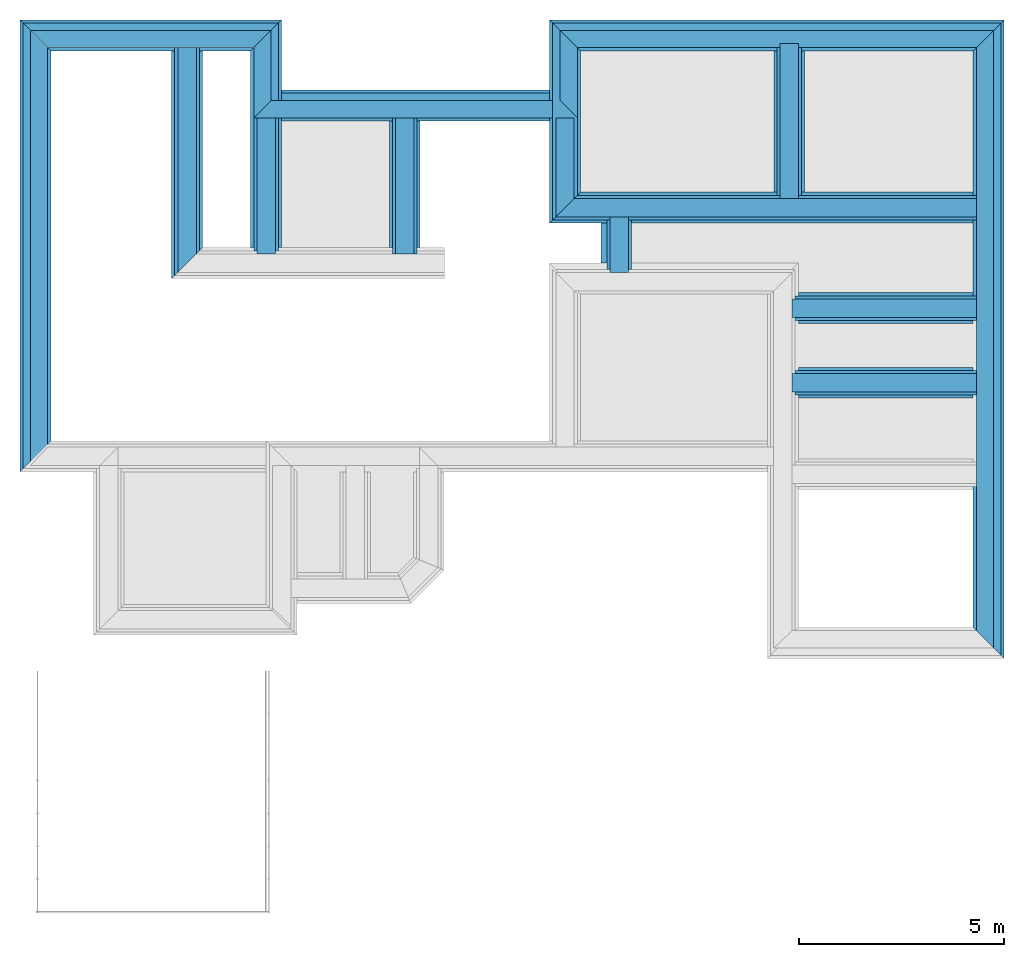
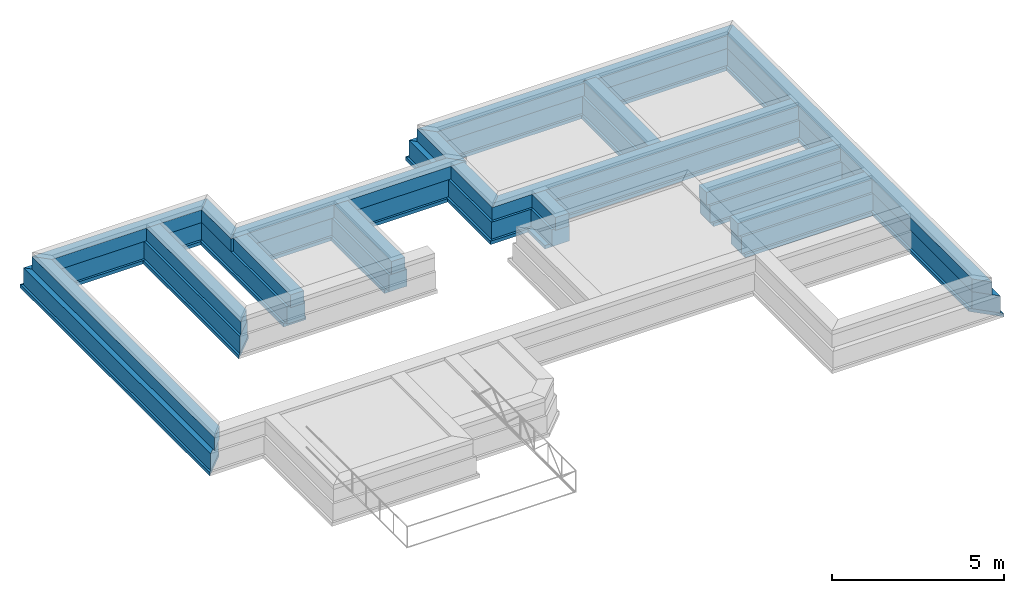
# One storey, part 6 of 7: 44 walls.
"""IFC4X3_ADD2 building model written with IfcOpenShell, lengths in metres."""

from ifc_helpers import new_model, entity, si_unit, converted_unit, frame, origin_with_axes, origin_2d_with_axis, place, context, subcontext, project, spatial, line, indexed_curve, outline, extrude, material, layer, layer_set, layer_usage, type_object, element, save


model = new_model("IFC4X3_ADD2")

# Units and contexts
model_context = context("Model", 3, precision=1e-05, world=origin_with_axes())
plan_context = context("Plan", 2, precision=1e-05, world=origin_2d_with_axis())
body_context = subcontext(model_context, "Body", "Model", "MODEL_VIEW")
ifc_project = project(units=[si_unit("VOLUMEUNIT", "CUBIC_METRE"), si_unit("LENGTHUNIT", "METRE"), converted_unit("PLANEANGLEUNIT", "degree", entity("IfcReal", 0.0174532925199433), si_unit("PLANEANGLEUNIT", "RADIAN"), dimensions=[0, 0, 0, 0, 0, 0, 0]), si_unit("AREAUNIT", "SQUARE_METRE")], contexts=[model_context, plan_context])

# Site, building, storey
site_placement = place(None, origin_with_axes())
site = spatial("IfcSite", under=ifc_project, at=site_placement)
building_placement = place(site_placement, origin_with_axes())
building = spatial("IfcBuilding", under=site, at=building_placement, Name="Building")
storey_placement = place(building_placement, frame((0.0, 0.0, -0.870000004768372), z_axis=(0.0, 0.0, 1.0), x_axis=(1.0, 0.0, 0.0)))
storey = spatial("IfcBuildingStorey", under=building, at=storey_placement, Name="Footing")

# Walls
ifc_material_1 = material(Name="Stone", Category="Structure")
ifc_layer_1 = layer(ifc_material_1, 0.449999988079071)
ifc_layer_set_1 = layer_set([ifc_layer_1])
ifc_layer_usage_1 = layer_usage(ifc_layer_set_1, "AXIS2", "POSITIVE", 0.0)
wall_type_1 = type_object("IfcWallType", Name="RRB_0.45W", PredefinedType="SHEAR", material=ifc_layer_set_1)
wall_1_placement = place(storey_placement, frame((23.9316806793215, 21.8778921531674, 0.719999998807908), z_axis=(0.0, 0.0, 1.0), x_axis=(3.13916473260163e-07, 0.999999999999951, 0.0)))
element("IfcWall", 1, at=wall_1_placement, inside=storey, type_object=wall_type_1, material=ifc_layer_usage_1, Name="Wall", context=body_context, shape_type="SweptSolid", body=[
    extrude(outline(indexed_curve([(0.44999998807909, 0.0), (0.450000117880316, 0.449999988079071), (4.22000942370352, 0.449999988079071), (4.22000939257221, 0.0)], segments=[line(1, 2, 3, 4, 1)])), origin_with_axes(), (0.0, 0.0, 1.0), 0.449999988079071),
])
ifc_layer_usage_2 = layer_usage(ifc_layer_set_1, "AXIS2", "POSITIVE", 0.0)
wall_2_placement = place(storey_placement, frame((18.4541816711426, 21.8778954520824, 0.719999998807908), z_axis=(0.0, 0.0, 1.0), x_axis=(0.999999999999822, -5.960464477538e-07, 0.0)))
element("IfcWall", 2, at=wall_2_placement, inside=storey, type_object=wall_type_1, material=ifc_layer_usage_2, Name="Wall", context=body_context, shape_type="SweptSolid", body=[
    extrude(outline(indexed_curve([(-0.449999988079037, 0.0), (5.60801341516185e-08, 0.449999988079071), (9.80748997480777, 0.449999988079071), (9.80749009981741, 0.0)], segments=[line(1, 2, 3, 4, 1)])), origin_with_axes(), (0.0, 0.0, 1.0), 0.449999988079071),
])
ifc_layer_usage_3 = layer_usage(ifc_layer_set_1, "AXIS2", "POSITIVE", 0.0)
wall_3_placement = place(storey_placement, frame((11.1843014234303, 20.5243861418143, 0.719999998807908), z_axis=(0.0, 0.0, 1.0), x_axis=(3.13916473260163e-07, 0.999999999999951, 0.0)))
element("IfcWall", 3, at=wall_3_placement, inside=storey, type_object=wall_type_1, material=ifc_layer_usage_3, Name="Wall", context=body_context, shape_type="SweptSolid", body=[
    extrude(outline(indexed_curve([(0.449999988079093, 0.0), (0.450000131326058, 0.449999988079071), (3.76552144418195, 0.449999988079071), (3.76552141414186, 0.0)], segments=[line(1, 2, 3, 4, 1)])), origin_with_axes(), (0.0, 0.0, 1.0), 0.449999988079071),
])
ifc_layer_usage_4 = layer_usage(ifc_layer_set_1, "AXIS2", "POSITIVE", 0.0)
wall_4_placement = place(storey_placement, frame((14.5602179044483, 20.5243840074145, 0.719999998807908), z_axis=(0.0, 0.0, 1.0), x_axis=(3.13916473260163e-07, 0.999999999999951, 0.0)))
element("IfcWall", 4, at=wall_4_placement, inside=storey, type_object=wall_type_1, material=ifc_layer_usage_4, Name="Wall", context=body_context, shape_type="SweptSolid", body=[
    extrude(outline(indexed_curve([(0.449999988079094, 0.0), (0.450000131326058, 0.449999988079071), (3.76552229320457, 0.449999988079071), (3.76552226325902, 0.0)], segments=[line(1, 2, 3, 4, 1)])), origin_with_axes(), (0.0, 0.0, 1.0), 0.449999988079071),
])
ifc_layer_usage_5 = layer_usage(ifc_layer_set_1, "AXIS2", "POSITIVE", 0.0)
wall_5_placement = place(storey_placement, frame((9.25813584268061, 20.5243873596191, 0.719999998807908), z_axis=(0.0, 0.0, 1.0), x_axis=(3.13916473260163e-07, 0.999999999999951, 0.0)))
element("IfcWall", 5, at=wall_5_placement, inside=storey, type_object=wall_type_1, material=ifc_layer_usage_5, Name="Wall", context=body_context, shape_type="SweptSolid", body=[
    extrude(outline(indexed_curve([(0.449999988079093, 0.0), (1.43246964352757e-07, 0.449999988079071), (5.57351498957041, 0.449999988079071), (5.57351496081623, 0.0)], segments=[line(1, 2, 3, 4, 1)])), origin_with_axes(), (0.0, 0.0, 1.0), 0.449999988079071),
])
ifc_layer_usage_6 = layer_usage(ifc_layer_set_1, "AXIS2", "POSITIVE", 0.0)
wall_6_placement = place(storey_placement, frame((23.7750180072631, 19.429594129323, 0.719999998807908), z_axis=(0.0, 0.0, 1.0), x_axis=(0.999999999999822, -5.960464477538e-07, 0.0)))
element("IfcWall", 6, at=wall_6_placement, inside=storey, type_object=wall_type_1, material=ifc_layer_usage_6, Name="Wall", context=body_context, shape_type="SweptSolid", body=[
    extrude(outline(indexed_curve([(0.0, 0.0), (-9.81330211661046e-08, 0.449999988079071), (4.48665286418751, 0.449999988079071), (4.48665298921001, 0.0)], segments=[line(1, 2, 3, 4, 1)])), origin_with_axes(), (0.0, 0.0, 1.0), 0.449999988079071),
])
ifc_layer_usage_7 = layer_usage(ifc_layer_set_1, "AXIS2", "POSITIVE", 0.0)
wall_7_placement = place(storey_placement, frame((19.7916831970215, 20.0728931427002, 0.719999998807908), z_axis=(0.0, 0.0, 1.0), x_axis=(3.13916473260163e-07, 0.999999999999951, 0.0)))
element("IfcWall", 7, at=wall_7_placement, inside=storey, type_object=wall_type_1, material=ifc_layer_usage_7, Name="Wall", context=body_context, shape_type="SweptSolid", body=[
    extrude(outline(indexed_curve([(0.449999988079079, 0.0), (0.450000081867921, 0.449999988079071), (1.80500099995072, 0.449999988079071), (1.80500087014949, 0.0)], segments=[line(1, 2, 3, 4, 1)])), origin_with_axes(), (0.0, 0.0, 1.0), 0.449999988079071),
])
ifc_layer_usage_8 = layer_usage(ifc_layer_set_1, "AXIS2", "POSITIVE", 0.0)
wall_8_placement = place(storey_placement, frame((18.466682434082, 21.8778953552246, 0.719999998807908), z_axis=(0.0, 0.0, 1.0), x_axis=(3.13916473260163e-07, 0.999999999999951, 0.0)))
element("IfcWall", 8, at=wall_8_placement, inside=storey, type_object=wall_type_1, material=ifc_layer_usage_8, Name="Wall", context=body_context, shape_type="SweptSolid", body=[
    extrude(outline(indexed_curve([(0.44999998807909, 0.0), (1.2982553602409e-07, 0.449999988079071), (2.41201430465592, 0.449999988079071), (2.41201460685087, 0.0)], segments=[line(1, 2, 3, 4, 1)])), origin_with_axes(), (0.0, 0.0, 1.0), 0.449999988079071),
])
ifc_layer_usage_9 = layer_usage(ifc_layer_set_1, "AXIS2", "POSITIVE", 0.0)
wall_9_placement = place(storey_placement, frame((23.7750173195989, 17.6093636453146, 0.719999998807908), z_axis=(0.0, 0.0, 1.0), x_axis=(0.999999999999822, -5.960464477538e-07, 0.0)))
element("IfcWall", 9, at=wall_9_placement, inside=storey, type_object=wall_type_1, material=ifc_layer_usage_9, Name="Wall", context=body_context, shape_type="SweptSolid", body=[
    extrude(outline(indexed_curve([(0.0, 0.0), (-9.81330211661044e-08, 0.449999988079071), (4.48665297295429, 0.449999988079071), (4.48665309797679, 0.0)], segments=[line(1, 2, 3, 4, 1)])), origin_with_axes(), (0.0, 0.0, 1.0), 0.449999988079071),
])
ifc_material_2 = material(Name="Plaster", Category="Finishes")
ifc_layer_2 = layer(ifc_material_2, 0.00999999977648258)
ifc_layer_3 = layer(ifc_material_1, 0.405000001192093)
ifc_layer_4 = layer(ifc_material_2, 0.00999999977648258)
ifc_layer_set_2 = layer_set([ifc_layer_2, ifc_layer_3, ifc_layer_4])
ifc_layer_usage_10 = layer_usage(ifc_layer_set_2, "AXIS2", "POSITIVE", 0.0)
wall_type_2 = type_object("IfcWallType", Name="RRB_0.425W", PredefinedType="SHEAR", material=ifc_layer_set_2)
wall_10_placement = place(storey_placement, frame((11.0843045825103, 26.4228992462159, 0.719999998807908), z_axis=(0.0, 0.0, 1.0), x_axis=(-0.999999999999924, 3.89414367418765e-07, 0.0)))
element("IfcWall", 10, at=wall_10_placement, inside=storey, type_object=wall_type_2, material=ifc_layer_usage_10, Name="Wall", context=body_context, shape_type="SweptSolid", body=[
    extrude(outline(indexed_curve([(0.0, 0.0), (0.424999984673434, 0.425000000745058), (5.44526225995521, 0.425000000745058), (5.87026229003865, 0.0)], segments=[line(1, 2, 3, 4, 1)])), origin_with_axes(), (0.0, 0.0, 1.0), 0.449999988079071),
])
ifc_layer_usage_11 = layer_usage(ifc_layer_set_2, "AXIS2", "POSITIVE", 0.0)
wall_11_placement = place(storey_placement, frame((28.6866732177093, 26.4228973778099, 0.719999998807908), z_axis=(0.0, 0.0, 1.0), x_axis=(-0.999999999999924, 3.89414367418765e-07, 0.0)))
element("IfcWall", 11, at=wall_11_placement, inside=storey, type_object=wall_type_2, material=ifc_layer_usage_11, Name="Wall", context=body_context, shape_type="SweptSolid", body=[
    extrude(outline(indexed_curve([(0.0, 0.0), (0.424999970499032, 0.425000000745058), (10.1449899350157, 0.425000000745058), (10.5699904372669, 0.0)], segments=[line(1, 2, 3, 4, 1)])), origin_with_axes(), (0.0, 0.0, 1.0), 0.449999988079071),
])
ifc_layer_usage_12 = layer_usage(ifc_layer_set_2, "AXIS2", "POSITIVE", 0.0)
wall_12_placement = place(storey_placement, frame((18.5416841319606, 24.7149047559503, 0.719999998807908), z_axis=(0.0, 0.0, 1.0), x_axis=(-0.999999999999924, 3.89414367418765e-07, 0.0)))
element("IfcWall", 12, at=wall_12_placement, inside=storey, type_object=wall_type_2, material=ifc_layer_usage_12, Name="Wall", context=body_context, shape_type="SweptSolid", body=[
    extrude(outline(indexed_curve([(0.425000000745095, 0.0), (-5.01506110114182e-07, 0.425000000745058), (7.88238015246545, 0.425000000745058), (7.45738016349185, 0.0)], segments=[line(1, 2, 3, 4, 1)])), origin_with_axes(), (0.0, 0.0, 1.0), 0.449999988079071),
])
ifc_layer_usage_13 = layer_usage(ifc_layer_set_2, "AXIS2", "POSITIVE", 0.0)
wall_13_placement = place(storey_placement, frame((28.6866684273878, 11.369344425688, 0.719999998807908), z_axis=(0.0, 0.0, 1.0), x_axis=(3.13916473260163e-07, 0.999999999999951, 0.0)))
element("IfcWall", 13, at=wall_13_placement, inside=storey, type_object=wall_type_2, material=ifc_layer_usage_13, Name="Wall", context=body_context, shape_type="SweptSolid", body=[
    extrude(outline(indexed_curve([(0.0, 0.0), (0.425000139605773, 0.425000000745058), (14.628552980733, 0.425000000745058), (15.0535529521226, 0.0)], segments=[line(1, 2, 3, 4, 1)])), origin_with_axes(), (0.0, 0.0, 1.0), 0.449999988079071),
])
ifc_layer_usage_14 = layer_usage(ifc_layer_set_2, "AXIS2", "POSITIVE", 0.0)
wall_14_placement = place(storey_placement, frame((5.63903903961169, 16.2660213158936, 0.719999998807908), z_axis=(0.0, 0.0, 1.0), x_axis=(3.13916473260163e-07, 0.999999999999951, 0.0)))
element("IfcWall", 14, at=wall_14_placement, inside=storey, type_object=wall_type_2, material=ifc_layer_usage_14, Name="Wall", context=body_context, shape_type="SweptSolid", body=[
    extrude(outline(indexed_curve([(0.0, 0.0), (-0.450000223773091, 0.425000000745058), (10.156880012591, 0.425000000745058), (9.73187998484762, 0.0)], segments=[line(1, 2, 3, 4, 1)])), origin_with_axes(), (0.0, 0.0, 1.0), 0.449999988079071),
])
ifc_layer_usage_15 = layer_usage(ifc_layer_set_2, "AXIS2", "POSITIVE", 0.0)
wall_15_placement = place(storey_placement, frame((11.0843039684693, 24.7149075947677, 0.719999998807908), z_axis=(0.0, 0.0, 1.0), x_axis=(3.13916473260163e-07, 0.999999999999951, 0.0)))
element("IfcWall", 15, at=wall_15_placement, inside=storey, type_object=wall_type_2, material=ifc_layer_usage_15, Name="Wall", context=body_context, shape_type="SweptSolid", body=[
    extrude(outline(indexed_curve([(0.0, 0.0), (-0.424999972373865, 0.425000000745058), (1.2829916777015, 0.425000000745058), (1.70799165144828, 0.0)], segments=[line(1, 2, 3, 4, 1)])), origin_with_axes(), (0.0, 0.0, 1.0), 0.449999988079071),
])
ifc_layer_usage_16 = layer_usage(ifc_layer_set_2, "AXIS2", "POSITIVE", 0.0)
wall_16_placement = place(storey_placement, frame((18.5416841319606, 24.7149047566126, 0.719999998807908), z_axis=(0.0, 0.0, 1.0), x_axis=(3.13916473260163e-07, 0.999999999999951, 0.0)))
element("IfcWall", 16, at=wall_16_placement, inside=storey, type_object=wall_type_2, material=ifc_layer_usage_16, Name="Wall", context=body_context, shape_type="SweptSolid", body=[
    extrude(outline(indexed_curve([(-0.425000000745059, 0.0), (2.83334474771024e-08, 0.425000000745058), (1.70799653596367, 0.425000000745058), (1.28299650586313, 0.0)], segments=[line(1, 2, 3, 4, 1)])), origin_with_axes(), (0.0, 0.0, 1.0), 0.449999988079071),
])
ifc_material_3 = material(Name="Wall")
ifc_layer_5 = layer(ifc_material_3, 0.600000023841858, Name="concrete")
ifc_layer_set_3 = layer_set([ifc_layer_5], Name="concrete")
ifc_layer_usage_17 = layer_usage(ifc_layer_set_3, "AXIS2", "POSITIVE", 0.0)
wall_type_3 = type_object("IfcWallType", Name="RRB_0.6W", PredefinedType="SHEAR", material=ifc_layer_set_3)
wall_17_placement = place(storey_placement, frame((18.5416813132168, 21.802896544815, 0.120000004768372), z_axis=(0.0, 0.0, 1.0), x_axis=(3.13916473260163e-07, 0.999999999999951, 0.0)))
element("IfcWall", 17, at=wall_17_placement, inside=storey, type_object=wall_type_3, material=ifc_layer_usage_17, Name="Wall", context=body_context, shape_type="SweptSolid", body=[
    extrude(outline(indexed_curve([(0.600000023841883, 0.0), (1.7306831381862e-07, 0.600000023841858), (4.79500596321352, 0.600000023841858), (4.19500589786325, 0.0)], segments=[line(1, 2, 3, 4, 1)])), origin_with_axes(), (0.0, 0.0, 1.0), 0.600000023841858),
])
ifc_layer_usage_18 = layer_usage(ifc_layer_set_3, "AXIS2", "POSITIVE", 0.0)
wall_18_placement = place(storey_placement, frame((24.0066795584563, 21.8028932526459, 0.120000004768372), z_axis=(0.0, 0.0, 1.0), x_axis=(3.13916473260163e-07, 0.999999999999951, 0.0)))
element("IfcWall", 18, at=wall_18_placement, inside=storey, type_object=wall_type_3, material=ifc_layer_usage_18, Name="Wall", context=body_context, shape_type="SweptSolid", body=[
    extrude(outline(indexed_curve([(0.600000023841883, 0.0), (0.600000196937945, 0.600000023841858), (4.19500713718583, 0.600000023841858), (4.19500709570516, 0.0)], segments=[line(1, 2, 3, 4, 1)])), origin_with_axes(), (0.0, 0.0, 1.0), 0.600000023841858),
])
ifc_layer_usage_19 = layer_usage(ifc_layer_set_3, "AXIS2", "POSITIVE", 0.0)
wall_19_placement = place(storey_placement, frame((9.33313562840178, 20.4493865966797, 0.120000004768372), z_axis=(0.0, 0.0, 1.0), x_axis=(3.13916473260163e-07, 0.999999999999951, 0.0)))
element("IfcWall", 19, at=wall_19_placement, inside=storey, type_object=wall_type_3, material=ifc_layer_usage_19, Name="Wall", context=body_context, shape_type="SweptSolid", body=[
    extrude(outline(indexed_curve([(0.600000023841888, 0.0), (1.91268479846074e-07, 0.600000023841858), (5.54851456538258, 0.600000023841858), (5.54851452704368, 0.0)], segments=[line(1, 2, 3, 4, 1)])), origin_with_axes(), (0.0, 0.0, 1.0), 0.600000023841858),
])
ifc_layer_usage_20 = layer_usage(ifc_layer_set_3, "AXIS2", "POSITIVE", 0.0)
wall_20_placement = place(storey_placement, frame((18.5416823246089, 24.8899059587721, 0.120000004768372), z_axis=(0.0, 0.0, 1.0), x_axis=(-0.999999999999924, 3.89414367418765e-07, 0.0)))
element("IfcWall", 20, at=wall_20_placement, inside=storey, type_object=wall_type_3, material=ifc_layer_usage_20, Name="Wall", context=body_context, shape_type="SweptSolid", body=[
    extrude(outline(indexed_curve([(0.600000023841859, 0.0), (0.599999986700795, 0.600000023841858), (7.2823786814523, 0.600000023841858), (7.28237872038916, 0.0)], segments=[line(1, 2, 3, 4, 1)])), origin_with_axes(), (0.0, 0.0, 1.0), 0.600000023841858),
])
ifc_layer_usage_21 = layer_usage(ifc_layer_set_3, "AXIS2", "POSITIVE", 0.0)
wall_21_placement = place(storey_placement, frame((18.5416813132168, 21.8028965443377, 0.120000004768372), z_axis=(0.0, 0.0, 1.0), x_axis=(0.999999999999822, -5.960464477538e-07, 0.0)))
element("IfcWall", 21, at=wall_21_placement, inside=storey, type_object=wall_type_3, material=ifc_layer_usage_21, Name="Wall", context=body_context, shape_type="SweptSolid", body=[
    extrude(outline(indexed_curve([(-0.60000002384188, 0.0), (-1.61120317371057e-07, 0.600000023841858), (9.71999143525005, 0.600000023841858), (9.71999160198862, 0.0)], segments=[line(1, 2, 3, 4, 1)])), origin_with_axes(), (0.0, 0.0, 1.0), 0.600000023841858),
])
ifc_layer_usage_22 = layer_usage(ifc_layer_set_3, "AXIS2", "POSITIVE", 0.0)
wall_22_placement = place(storey_placement, frame((11.2593041573632, 26.597900419831, 0.120000004768372), z_axis=(0.0, 0.0, 1.0), x_axis=(-0.999999999999924, 3.89414367418765e-07, 0.0)))
element("IfcWall", 22, at=wall_22_placement, inside=storey, type_object=wall_type_3, material=ifc_layer_usage_22, Name="Wall", context=body_context, shape_type="SweptSolid", body=[
    extrude(outline(indexed_curve([(0.0, 0.0), (0.599999984828332, 0.600000023841858), (5.62026181561733, 0.600000023841858), (6.22026188091619, 0.0)], segments=[line(1, 2, 3, 4, 1)])), origin_with_axes(), (0.0, 0.0, 1.0), 0.600000023841858),
])
ifc_layer_usage_23 = layer_usage(ifc_layer_set_3, "AXIS2", "POSITIVE", 0.0)
wall_23_placement = place(storey_placement, frame((23.8500163785197, 19.3545952290297, 0.120000004768372), z_axis=(0.0, 0.0, 1.0), x_axis=(0.999999999999822, -5.960464477538e-07, 0.0)))
element("IfcWall", 23, at=wall_23_placement, inside=storey, type_object=wall_type_3, material=ifc_layer_usage_23, Name="Wall", context=body_context, shape_type="SweptSolid", body=[
    extrude(outline(indexed_curve([(0.0, 0.0), (-1.64834769819655e-07, 0.600000023841858), (4.41165559102303, 0.600000023841858), (4.4116557577616, 0.0)], segments=[line(1, 2, 3, 4, 1)])), origin_with_axes(), (0.0, 0.0, 1.0), 0.600000023841858),
])
ifc_layer_usage_24 = layer_usage(ifc_layer_set_3, "AXIS2", "POSITIVE", 0.0)
wall_24_placement = place(storey_placement, frame((11.2593021628258, 20.4493853779994, 0.120000004768372), z_axis=(0.0, 0.0, 1.0), x_axis=(3.13916473260163e-07, 0.999999999999951, 0.0)))
element("IfcWall", 24, at=wall_24_placement, inside=storey, type_object=wall_type_3, material=ifc_layer_usage_24, Name="Wall", context=body_context, shape_type="SweptSolid", body=[
    extrude(outline(indexed_curve([(0.600000023841888, 0.0), (0.600000215110368, 0.600000023841858), (5.54851505632895, 0.600000023841858), (6.1485150418319, 0.0)], segments=[line(1, 2, 3, 4, 1)])), origin_with_axes(), (0.0, 0.0, 1.0), 0.600000023841858),
])
ifc_layer_usage_25 = layer_usage(ifc_layer_set_3, "AXIS2", "POSITIVE", 0.0)
wall_25_placement = place(storey_placement, frame((19.8666820526127, 19.9978935266985, 0.120000004768372), z_axis=(0.0, 0.0, 1.0), x_axis=(3.13916473260163e-07, 0.999999999999951, 0.0)))
element("IfcWall", 25, at=wall_25_placement, inside=storey, type_object=wall_type_3, material=ifc_layer_usage_25, Name="Wall", context=body_context, shape_type="SweptSolid", body=[
    extrude(outline(indexed_curve([(0.600000023841884, 0.0), (0.600000200488681, 0.600000023841858), (1.8050023934961, 0.600000023841858), (1.80500222042779, 0.0)], segments=[line(1, 2, 3, 4, 1)])), origin_with_axes(), (0.0, 0.0, 1.0), 0.600000023841858),
])
ifc_layer_usage_26 = layer_usage(ifc_layer_set_3, "AXIS2", "POSITIVE", 0.0)
wall_26_placement = place(storey_placement, frame((23.8500157936399, 17.5343647450212, 0.120000004768372), z_axis=(0.0, 0.0, 1.0), x_axis=(0.999999999999822, -5.960464477538e-07, 0.0)))
element("IfcWall", 26, at=wall_26_placement, inside=storey, type_object=wall_type_3, material=ifc_layer_usage_26, Name="Wall", context=body_context, shape_type="SweptSolid", body=[
    extrude(outline(indexed_curve([(0.0, 0.0), (-1.64834769833533e-07, 0.600000023841858), (4.41165559679863, 0.600000023841858), (4.4116557635372, 0.0)], segments=[line(1, 2, 3, 4, 1)])), origin_with_axes(), (0.0, 0.0, 1.0), 0.600000023841858),
])
ifc_layer_usage_27 = layer_usage(ifc_layer_set_3, "AXIS2", "POSITIVE", 0.0)
wall_27_placement = place(storey_placement, frame((28.8616744645718, 26.5978985124831, 0.120000004768372), z_axis=(0.0, 0.0, 1.0), x_axis=(-0.999999999999924, 3.89414367418765e-07, 0.0)))
element("IfcWall", 27, at=wall_27_placement, inside=storey, type_object=wall_type_3, material=ifc_layer_usage_27, Name="Wall", context=body_context, shape_type="SweptSolid", body=[
    extrude(outline(indexed_curve([(0.0, 0.0), (0.599999981082541, 0.600000023841858), (10.3199915436642, 0.600000023841858), (10.9199916047727, 0.0)], segments=[line(1, 2, 3, 4, 1)])), origin_with_axes(), (0.0, 0.0, 1.0), 0.600000023841858),
])
ifc_layer_usage_28 = layer_usage(ifc_layer_set_3, "AXIS2", "POSITIVE", 0.0)
wall_28_placement = place(storey_placement, frame((28.8616695639489, 11.1943442232811, 0.120000004768372), z_axis=(0.0, 0.0, 1.0), x_axis=(3.13916473260163e-07, 0.999999999999951, 0.0)))
element("IfcWall", 28, at=wall_28_placement, inside=storey, type_object=wall_type_3, material=ifc_layer_usage_28, Name="Wall", context=body_context, shape_type="SweptSolid", body=[
    extrude(outline(indexed_curve([(0.0, 0.0), (0.600000219346542, 0.600000023841858), (14.8035543096255, 0.600000023841858), (15.4035542919589, 0.0)], segments=[line(1, 2, 3, 4, 1)])), origin_with_axes(), (0.0, 0.0, 1.0), 0.600000023841858),
])
ifc_layer_usage_29 = layer_usage(ifc_layer_set_3, "AXIS2", "POSITIVE", 0.0)
wall_29_placement = place(storey_placement, frame((5.63903901606797, 16.3410209768514, 0.120000004768372), z_axis=(0.0, 0.0, 1.0), x_axis=(3.13916473260163e-07, 0.999999999999951, 0.0)))
element("IfcWall", 29, at=wall_29_placement, inside=storey, type_object=wall_type_3, material=ifc_layer_usage_29, Name="Wall", context=body_context, shape_type="SweptSolid", body=[
    extrude(outline(indexed_curve([(0.0, 0.0), (-0.5999999850636, 0.600000023841858), (10.2568816047363, 0.600000023841858), (9.6568815425555, 0.0)], segments=[line(1, 2, 3, 4, 1)])), origin_with_axes(), (0.0, 0.0, 1.0), 0.600000023841858),
])
ifc_layer_usage_30 = layer_usage(ifc_layer_set_3, "AXIS2", "POSITIVE", 0.0)
wall_30_placement = place(storey_placement, frame((14.6352186203005, 20.3743844314932, 0.120000004768372), z_axis=(0.0, 0.0, 1.0), x_axis=(3.13916473260163e-07, 0.999999999999951, 0.0)))
element("IfcWall", 30, at=wall_30_placement, inside=storey, type_object=wall_type_3, material=ifc_layer_usage_30, Name="Wall", context=body_context, shape_type="SweptSolid", body=[
    extrude(outline(indexed_curve([(0.600000023841888, 0.0), (0.600000215389809, 0.600000023841858), (3.91552302920591, 0.600000023841858), (3.9155229893344, 0.0)], segments=[line(1, 2, 3, 4, 1)])), origin_with_axes(), (0.0, 0.0, 1.0), 0.600000023841858),
])
ifc_layer_6 = layer(ifc_material_3, 0.75)
ifc_layer_set_4 = layer_set([ifc_layer_6])
ifc_layer_usage_31 = layer_usage(ifc_layer_set_4, "AXIS2", "POSITIVE", 0.0)
wall_type_4 = type_object("IfcWallType", PredefinedType="SHEAR", material=ifc_layer_set_4)
wall_31_placement = place(storey_placement, frame((11.3343043265543, 26.6729009988723, 0.0), z_axis=(0.0, 0.0, 1.0), x_axis=(-0.999999999999924, 3.89414367418765e-07, 0.0)))
element("IfcWall", 31, at=wall_31_placement, inside=storey, type_object=wall_type_4, material=ifc_layer_usage_31, Name="Wall", context=body_context, shape_type="SweptSolid", body=[
    extrude(outline(indexed_curve([(0.0, 0.0), (0.749999951139541, 0.75), (5.62026220810672, 0.75), (6.37026225996308, 0.0)], segments=[line(1, 2, 3, 4, 1)])), origin_with_axes(), (0.0, 0.0, 1.0), 0.119999997317791),
])
ifc_layer_usage_32 = layer_usage(ifc_layer_set_4, "AXIS2", "POSITIVE", 0.0)
wall_32_placement = place(storey_placement, frame((18.6166831257379, 24.9649062643639, 0.0), z_axis=(0.0, 0.0, 1.0), x_axis=(-0.999999999999924, 3.89414367418765e-07, 0.0)))
element("IfcWall", 32, at=wall_32_placement, inside=storey, type_object=wall_type_4, material=ifc_layer_usage_32, Name="Wall", context=body_context, shape_type="SweptSolid", body=[
    extrude(outline(indexed_curve([(0.750000000000001, 0.0), (0.749999954027897, 0.75), (7.28237930416929, 0.75), (7.28237935302975, 0.0)], segments=[line(1, 2, 3, 4, 1)])), origin_with_axes(), (0.0, 0.0, 1.0), 0.119999997317791),
])
ifc_layer_usage_33 = layer_usage(ifc_layer_set_4, "AXIS2", "POSITIVE", 0.0)
wall_33_placement = place(storey_placement, frame((5.71403878159405, 16.416021684612, 0.0), z_axis=(0.0, 0.0, 1.0), x_axis=(3.13916473260163e-07, 0.999999999999951, 0.0)))
element("IfcWall", 33, at=wall_33_placement, inside=storey, type_object=wall_type_4, material=ifc_layer_usage_33, Name="Wall", context=body_context, shape_type="SweptSolid", body=[
    extrude(outline(indexed_curve([(0.0, 0.0), (-0.74999995152718, 0.75), (10.2568814856018, 0.75), (9.50688143767821, 0.0)], segments=[line(1, 2, 3, 4, 1)])), origin_with_axes(), (0.0, 0.0, 1.0), 0.119999997317791),
])
ifc_layer_usage_34 = layer_usage(ifc_layer_set_4, "AXIS2", "POSITIVE", 0.0)
wall_34_placement = place(storey_placement, frame((11.3343022841534, 20.3743867690882, 0.0), z_axis=(0.0, 0.0, 1.0), x_axis=(3.13916473260163e-07, 0.999999999999951, 0.0)))
element("IfcWall", 34, at=wall_34_placement, inside=storey, type_object=wall_type_4, material=ifc_layer_usage_34, Name="Wall", context=body_context, shape_type="SweptSolid", body=[
    extrude(outline(indexed_curve([(0.750000000000038, 0.0), (0.750000239434929, 0.75), (5.54851427770804, 0.75), (6.29851422978442, 0.0)], segments=[line(1, 2, 3, 4, 1)])), origin_with_axes(), (0.0, 0.0, 1.0), 0.119999997317791),
])
ifc_layer_usage_35 = layer_usage(ifc_layer_set_4, "AXIS2", "POSITIVE", 0.0)
wall_35_placement = place(storey_placement, frame((9.40813504085922, 20.3743879886661, 0.0), z_axis=(0.0, 0.0, 1.0), x_axis=(3.13916473260163e-07, 0.999999999999951, 0.0)))
element("IfcWall", 35, at=wall_35_placement, inside=storey, type_object=wall_type_4, material=ifc_layer_usage_35, Name="Wall", context=body_context, shape_type="SweptSolid", body=[
    extrude(outline(indexed_curve([(0.750000000000038, 0.0), (2.39434890939613e-07, 0.75), (5.54851378586441, 0.75), (5.54851373794079, 0.0)], segments=[line(1, 2, 3, 4, 1)])), origin_with_axes(), (0.0, 0.0, 1.0), 0.119999997317791),
])
ifc_layer_usage_36 = layer_usage(ifc_layer_set_4, "AXIS2", "POSITIVE", 0.0)
wall_36_placement = place(storey_placement, frame((14.7102183011036, 20.3743844742758, 0.0), z_axis=(0.0, 0.0, 1.0), x_axis=(3.13916473260163e-07, 0.999999999999951, 0.0)))
element("IfcWall", 36, at=wall_36_placement, inside=storey, type_object=wall_type_4, material=ifc_layer_usage_36, Name="Wall", context=body_context, shape_type="SweptSolid", body=[
    extrude(outline(indexed_curve([(0.750000000000038, 0.0), (0.750000241542329, 0.75), (3.84052332842058, 0.75), (3.84052328013086, 0.0)], segments=[line(1, 2, 3, 4, 1)])), origin_with_axes(), (0.0, 0.0, 1.0), 0.119999997317791),
])
ifc_layer_usage_37 = layer_usage(ifc_layer_set_4, "AXIS2", "POSITIVE", 0.0)
wall_37_placement = place(storey_placement, frame((18.6166820631397, 21.7278964521527, 0.0), z_axis=(0.0, 0.0, 1.0), x_axis=(3.13916473260163e-07, 0.999999999999951, 0.0)))
element("IfcWall", 37, at=wall_37_placement, inside=storey, type_object=wall_type_4, material=ifc_layer_usage_37, Name="Wall", context=body_context, shape_type="SweptSolid", body=[
    extrude(outline(indexed_curve([(0.750000000000031, 0.0), (2.16893068331891e-07, 0.75), (4.94500712925562, 0.75), (4.1950070773701, 0.0)], segments=[line(1, 2, 3, 4, 1)])), origin_with_axes(), (0.0, 0.0, 1.0), 0.119999997317791),
])
ifc_layer_usage_38 = layer_usage(ifc_layer_set_4, "AXIS2", "POSITIVE", 0.0)
wall_38_placement = place(storey_placement, frame((24.0816802712711, 21.7278931602364, 0.0), z_axis=(0.0, 0.0, 1.0), x_axis=(3.13916473260163e-07, 0.999999999999951, 0.0)))
element("IfcWall", 38, at=wall_38_placement, inside=storey, type_object=wall_type_4, material=ifc_layer_usage_38, Name="Wall", context=body_context, shape_type="SweptSolid", body=[
    extrude(outline(indexed_curve([(0.750000000000031, 0.0), (0.750000216335415, 0.75), (4.19500832754658, 0.75), (4.19500827566106, 0.0)], segments=[line(1, 2, 3, 4, 1)])), origin_with_axes(), (0.0, 0.0, 1.0), 0.119999997317791),
])
ifc_layer_usage_39 = layer_usage(ifc_layer_set_4, "AXIS2", "POSITIVE", 0.0)
wall_39_placement = place(storey_placement, frame((28.9366757609006, 26.6728995759628, 0.0), z_axis=(0.0, 0.0, 1.0), x_axis=(-0.999999999999924, 3.89414367418765e-07, 0.0)))
element("IfcWall", 39, at=wall_39_placement, inside=storey, type_object=wall_type_4, material=ifc_layer_usage_39, Name="Wall", context=body_context, shape_type="SweptSolid", body=[
    extrude(outline(indexed_curve([(0.0, 0.0), (0.749999954027897, 0.75), (10.3199920334468, 0.75), (11.069992080249, 0.0)], segments=[line(1, 2, 3, 4, 1)])), origin_with_axes(), (0.0, 0.0, 1.0), 0.119999997317791),
])
ifc_layer_usage_40 = layer_usage(ifc_layer_set_4, "AXIS2", "POSITIVE", 0.0)
wall_40_placement = place(storey_placement, frame((28.9366708072764, 11.1193440653482, 0.0), z_axis=(0.0, 0.0, 1.0), x_axis=(3.13916473260163e-07, 0.999999999999951, 0.0)))
element("IfcWall", 40, at=wall_40_placement, inside=storey, type_object=wall_type_4, material=ifc_layer_usage_40, Name="Wall", context=body_context, shape_type="SweptSolid", body=[
    extrude(outline(indexed_curve([(0.0, 0.0), (0.750000244380841, 0.75), (14.8035555625009, 0.75), (15.5535555106153, 0.0)], segments=[line(1, 2, 3, 4, 1)])), origin_with_axes(), (0.0, 0.0, 1.0), 0.119999997317791),
])
ifc_layer_usage_41 = layer_usage(ifc_layer_set_4, "AXIS2", "POSITIVE", 0.0)
wall_41_placement = place(storey_placement, frame((19.8666819737333, 19.9978927276556, 0.0), z_axis=(0.0, 0.0, 1.0), x_axis=(3.13916473260163e-07, 0.999999999999951, 0.0)))
element("IfcWall", 41, at=wall_41_placement, inside=storey, type_object=wall_type_4, material=ifc_layer_usage_41, Name="Wall", context=body_context, shape_type="SweptSolid", body=[
    extrude(outline(indexed_curve([(0.750000000000032, 0.0), (0.750000220808519, 0.75), (1.73000318787769, 0.75), (1.7300029715423, 0.0)], segments=[line(1, 2, 3, 4, 1)])), origin_with_axes(), (0.0, 0.0, 1.0), 0.119999997317791),
])
ifc_layer_usage_42 = layer_usage(ifc_layer_set_4, "AXIS2", "POSITIVE", 0.0)
wall_42_placement = place(storey_placement, frame((23.9250164942423, 17.4593635957983, 0.0), z_axis=(0.0, 0.0, 1.0), x_axis=(0.999999999999822, -5.960464477538e-07, 0.0)))
element("IfcWall", 42, at=wall_42_placement, inside=storey, type_object=wall_type_4, material=ifc_layer_usage_42, Name="Wall", context=body_context, shape_type="SweptSolid", body=[
    extrude(outline(indexed_curve([(0.0, 0.0), (-2.0609037037268e-07, 0.75), (4.26165612139124, 0.75), (4.26165632984506, 0.0)], segments=[line(1, 2, 3, 4, 1)])), origin_with_axes(), (0.0, 0.0, 1.0), 0.119999997317791),
])
ifc_layer_usage_43 = layer_usage(ifc_layer_set_4, "AXIS2", "POSITIVE", 0.0)
wall_43_placement = place(storey_placement, frame((23.9250164031982, 19.2795944213867, 4.44089209850063e-16), z_axis=(0.0, 0.0, 1.0), x_axis=(0.999999999999822, -5.960464477538e-07, 0.0)))
element("IfcWall", 43, at=wall_43_placement, inside=storey, type_object=wall_type_4, material=ifc_layer_usage_43, Name="Wall", context=body_context, shape_type="SweptSolid", body=[
    extrude(outline(indexed_curve([(0.0, 0.0), (-2.06090370372681e-07, 0.75), (4.26165611541895, 0.75), (4.26165632387277, 0.0)], segments=[line(1, 2, 3, 4, 1)])), origin_with_axes(), (0.0, 0.0, 1.0), 0.119999997317791),
])
ifc_layer_usage_44 = layer_usage(ifc_layer_set_4, "AXIS2", "POSITIVE", 0.0)
wall_44_placement = place(storey_placement, frame((18.6166820635789, 21.7278964521527, 0.0), z_axis=(0.0, 0.0, 1.0), x_axis=(0.999999999999822, -5.960464477538e-07, 0.0)))
element("IfcWall", 44, at=wall_44_placement, inside=storey, type_object=wall_type_4, material=ifc_layer_usage_44, Name="Wall", context=body_context, shape_type="SweptSolid", body=[
    extrude(outline(indexed_curve([(-0.750000000000027, 0.0), (-2.01709705883623e-07, 0.75), (9.56999191034836, 0.75), (9.56999211880218, 0.0)], segments=[line(1, 2, 3, 4, 1)])), origin_with_axes(), (0.0, 0.0, 1.0), 0.119999997317791),
])

save(model, "model.ifc")
